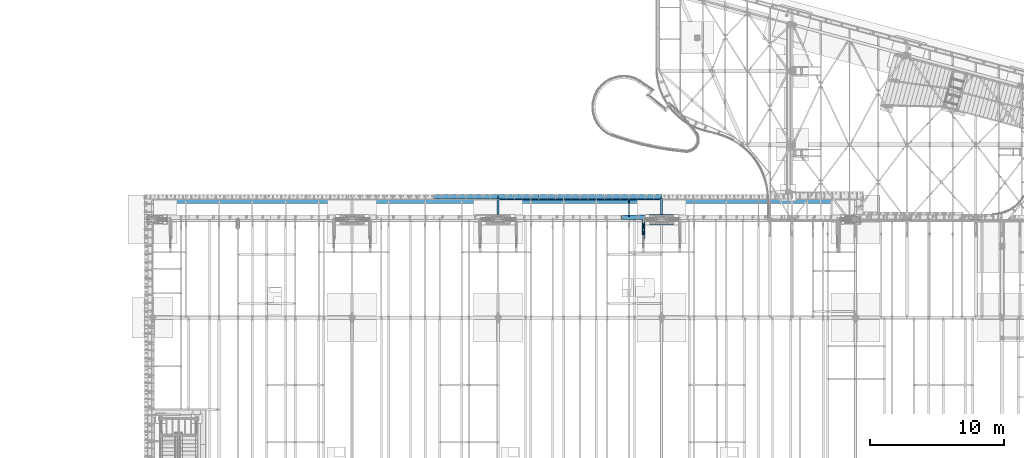
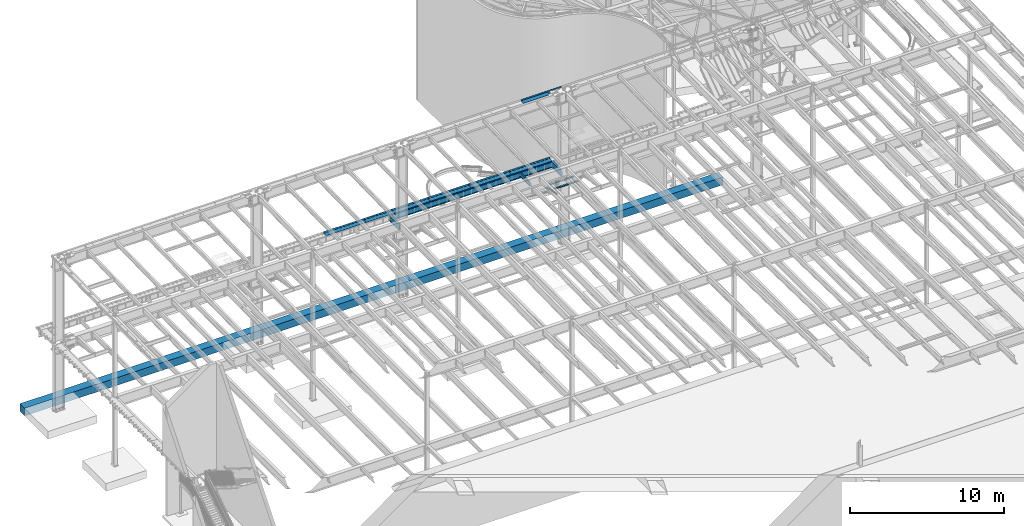
# One storey, part 1136 of 1763: 16 beams, 9 elements without a shape of their own.
"""IFC2X3 building model written with IfcOpenShell, lengths in millimetres."""

from ifc_helpers import new_model, si_unit, frame, origin_with_axes, place, context, subcontext, project, spatial, faceted_brep, material, type_object, element, aggregate, save


model = new_model("IFC2X3")

# Units and contexts
model_context = context("Model", 3, precision=1e-05, world=origin_with_axes())
body_context = subcontext(model_context, "Body", "Model", "MODEL_VIEW")
ifc_project = project(units=[si_unit("LENGTHUNIT", "METRE", prefix="MILLI"), si_unit("AREAUNIT", "SQUARE_METRE"), si_unit("VOLUMEUNIT", "CUBIC_METRE"), si_unit("MASSUNIT", "GRAM", prefix="KILO"), si_unit("TIMEUNIT", "SECOND"), si_unit("PLANEANGLEUNIT", "RADIAN"), si_unit("SOLIDANGLEUNIT", "STERADIAN"), si_unit("THERMODYNAMICTEMPERATUREUNIT", "DEGREE_CELSIUS"), si_unit("LUMINOUSINTENSITYUNIT", "LUMEN")], contexts=[model_context])

# Site, building, storey
site_placement = place(None, origin_with_axes())
site = spatial("IfcSite", under=ifc_project, at=site_placement, CompositionType="ELEMENT")
building_placement = place(site_placement, origin_with_axes())
building = spatial("IfcBuilding", under=site, at=building_placement, Name="Undefined", CompositionType="ELEMENT")
storey_placement = place(building_placement, origin_with_axes())
storey = spatial("IfcBuildingStorey", under=building, at=storey_placement, Name="Undefined", CompositionType="ELEMENT", Elevation=0.0)

# Assembly, beams
assembly_1_placement = place(storey_placement, origin_with_axes())
assembly_1 = element("IfcElementAssembly", 1, at=assembly_1_placement, inside=storey, Name="COLUMN", AssemblyPlace="NOTDEFINED", PredefinedType="RIGID_FRAME")
ifc_material_1 = material(Name="STEEL/A572-50")
beam_type_1 = type_object("IfcBeamType", PredefinedType="NOTDEFINED")
beam_1_placement = place(assembly_1_placement, frame((-48505.4997736984, 52409.725, 4433.8875), z_axis=(0.0, -1.0, 0.0), x_axis=(-1.0, 0.0, 0.0)))
beam_1 = element("IfcBeam", 2, at=beam_1_placement, type_object=beam_type_1, material=ifc_material_1, Name="PLATE", context=body_context, shape_type="Brep", body=[
    faceted_brep([(0.0, 14.2875000000004, -79.375), (0.0, 14.2875000000004, 79.375), (1793.875, 14.2875000000004, 79.375), (1793.875, 14.2875000000004, -79.375), (0.0, -14.2875000000004, 79.375), (1793.875, -14.2875000000004, 79.375), (0.0, -14.2875000000004, -79.375), (1793.875, -14.2875000000004, -79.375)], [[[0, 1, 2, 3]], [[1, 4, 5, 2]], [[4, 6, 7, 5]], [[6, 0, 3, 7]], [[5, 7, 3, 2]], [[6, 4, 1, 0]]]),
])
beam_2_placement = place(assembly_1_placement, frame((-48505.4997736984, 51831.875, 4433.8875), z_axis=(0.0, -1.0, 0.0), x_axis=(-1.0, 0.0, 0.0)))
beam_2 = element("IfcBeam", 3, at=beam_2_placement, type_object=beam_type_1, material=ifc_material_1, Name="PLATE", context=body_context, shape_type="Brep", body=[
    faceted_brep([(0.0, 14.2875000000004, -79.375), (0.0, 14.2875000000004, 79.375), (1793.875, 14.2875000000004, 79.375), (1793.875, 14.2875000000004, -79.375), (0.0, -14.2875000000004, 79.375), (1793.875, -14.2875000000004, 79.375), (0.0, -14.2875000000004, -79.375), (1793.875, -14.2875000000004, -79.375)], [[[0, 1, 2, 3]], [[1, 4, 5, 2]], [[4, 6, 7, 5]], [[6, 0, 3, 7]], [[5, 7, 3, 2]], [[6, 4, 1, 0]]]),
])
aggregate(assembly_1, [beam_1, beam_2])

assembly_2_placement = place(storey_placement, origin_with_axes())
assembly_2 = element("IfcElementAssembly", 4, at=assembly_2_placement, inside=storey, Name="ANGLE BRACE", AssemblyPlace="NOTDEFINED", PredefinedType="RIGID_FRAME")
ifc_material_2 = material(Name="STEEL/A36")
beam_type_2 = type_object("IfcBeamType", Name="L4X3X5/16", PredefinedType="NOTDEFINED")
beam_3_placement = place(assembly_2_placement, frame((-50799.4372736984, 50680.4564530846, 4820.75267554856), z_axis=(0.0, -0.2072236520035, -0.978293595016513), x_axis=(0.0, 0.978293600950479, -0.20722362398951)))
beam_3 = element("IfcBeam", 5, at=beam_3_placement, type_object=beam_type_2, material=ifc_material_2, Name="ANGLE BRACE", ObjectType="L4X3X5/16", context=body_context, shape_type="Brep", body=[
    faceted_brep([(1.45519152283669e-10, 38.0999999999985, -50.7999999999993), (1.45519152283669e-10, 38.0999999999985, 50.7999999999993), (1427.42255777739, 38.0999999999985, 50.7999999995518), (1427.42255777754, 38.0999999999985, -50.8000000004868), (-7.27595761418343e-11, 30.1624999999985, 50.8000000000211), (1427.42255777739, 30.1624999999985, 50.7999999995518), (7.27595761418343e-11, 30.1624999999985, -42.8625000000175), (1427.42255777754, 30.1624999999985, -42.8625000004868), (7.27595761418343e-11, -38.0999999999985, -42.8625000000175), (1427.42255777754, -38.0999999999985, -42.8625000004868), (-1.23691279441118e-10, -38.1000000000022, -50.7999999999993), (1427.42255777754, -38.0999999999985, -50.8000000004868)], [[[0, 1, 2, 3]], [[1, 4, 5, 2]], [[4, 6, 7, 5]], [[6, 8, 9, 7]], [[8, 10, 11, 9]], [[10, 0, 3, 11]], [[5, 7, 9, 11, 3, 2]], [[10, 8, 6, 4, 1, 0]]]),
])
beam_4_placement = place(assembly_2_placement, frame((-50713.7122736983, 52076.9355387112, 4524.94833056974), z_axis=(0.0, -0.2072236520035, -0.978293595016513), x_axis=(0.0, -0.978293595016513, 0.207223652003498)))
beam_4 = element("IfcBeam", 6, at=beam_4_placement, type_object=beam_type_2, material=ifc_material_2, Name="ANGLE BRACE", ObjectType="L4X3X5/16", context=body_context, shape_type="Brep", body=[
    faceted_brep([(1.45519152283669e-10, 38.0999999999985, -50.7999999999993), (1.45519152283669e-10, 38.0999999999985, 50.7999999999993), (1427.46422513096, 38.0999999999985, 50.7999999991189), (1427.46422513096, 38.0999999999985, -50.8000000008396), (-7.27595761418343e-11, 30.1624999999985, 50.8000000000211), (1427.46422513096, 30.1624999999985, 50.7999999991189), (7.27595761418343e-11, 30.1624999999985, -42.8625000000175), (1427.46422513096, 30.1624999999985, -42.8625000008433), (7.27595761418343e-11, -38.0999999999985, -42.8625000000175), (1427.46422513096, -38.0999999999985, -42.8625000008433), (-1.23691279441118e-10, -38.1000000000022, -50.7999999999993), (1427.46422513096, -38.0999999999985, -50.8000000008396)], [[[0, 1, 2, 3]], [[1, 4, 5, 2]], [[4, 6, 7, 5]], [[6, 8, 9, 7]], [[8, 10, 11, 9]], [[10, 0, 3, 11]], [[5, 7, 9, 11, 3, 2]], [[10, 8, 6, 4, 1, 0]]]),
])
aggregate(assembly_2, [beam_3, beam_4])

# Assembly, beam
assembly_3_placement = place(storey_placement, origin_with_axes())
assembly_3 = element("IfcElementAssembly", 7, at=assembly_3_placement, inside=storey, Name="BEAM", AssemblyPlace="NOTDEFINED", PredefinedType="RIGID_FRAME")
beam_type_3 = type_object("IfcBeamType", PredefinedType="NOTDEFINED")
beam_5_placement = place(assembly_3_placement, frame((-50926.4372736983, 52133.5000002128, 11752.2624917654), z_axis=(-1.0, 0.0, 0.0), x_axis=(0.0, 1.0, 0.0)))
beam_5 = element("IfcBeam", 8, at=beam_5_placement, type_object=beam_type_3, material=ifc_material_2, Name="BENT_PLATE", context=body_context, shape_type="Brep", body=[
    faceted_brep([(0.0, -4.76250000000073, -392.112609374992), (0.0, 4.76250000000073, -392.112609374992), (133.350000000006, 4.76250000000073, -392.112609374992), (133.350000000006, -4.76250000000073, -392.112609374992), (133.350000000006, 4.76250000000073, -595.31249951171), (133.350000000006, -4.76250000000073, -595.31249951171), (327.024987792967, -4.76250000000073, -595.31347607421), (327.024987792967, 4.76250000000073, -595.31347607421), (327.024987792975, 4.76250000000073, -1520.8245), (327.024987792975, -4.76250000000073, -1520.8245), (336.549987792969, 4.76250000000073, 1520.8245), (0.0, 4.76250000000073, 1520.8245), (0.0, -4.76250000000073, 1520.8245), (327.024987792975, -4.76250000000073, 1520.8245), (327.024987792975, -122.237499999999, 1520.8245), (336.549987792969, -122.237499999999, 1520.8245), (336.549987792969, 4.76250000000073, -1520.8245), (336.549987792969, -122.237499999999, -1520.8245), (327.024987792975, -122.237499999999, -1520.8245), (327.024987792975, -99.5375007629336, -1520.8245)], [[[0, 1, 2, 3]], [[3, 2, 4, 5]], [[6, 7, 8, 9]], [[5, 4, 7, 6]], [[10, 11, 12, 13, 14, 15]], [[16, 10, 15, 17]], [[14, 18, 17, 15]], [[13, 6, 9, 19, 18, 14]], [[16, 17, 18, 19, 9, 8]], [[2, 1, 11, 10, 16, 8, 7, 4]], [[12, 11, 1, 0]], [[13, 12, 0, 3, 5, 6]]]),
])
aggregate(assembly_3, [beam_5])

assembly_4_placement = place(storey_placement, origin_with_axes())
assembly_4 = element("IfcElementAssembly", 9, at=assembly_4_placement, inside=storey, Name="BEAM", AssemblyPlace="NOTDEFINED", PredefinedType="RIGID_FRAME")
beam_type_4 = type_object("IfcBeamType", PredefinedType="NOTDEFINED")
beam_6_placement = place(assembly_4_placement, frame((-62470.7372736984, 53657.5, 5199.0625), z_axis=(1.0, 0.0, 0.0), x_axis=(0.0, 1.0, 0.0)))
beam_6 = element("IfcBeam", 10, at=beam_6_placement, type_object=beam_type_4, material=ifc_material_2, Name="BENT PLATE", context=body_context, shape_type="Brep", body=[
    faceted_brep([(0.0, -4.76249999999982, -876.300000000003), (0.0, -4.76249999999982, 876.300000000003), (0.0, 4.76249999999982, 876.300000000003), (0.0, 4.76249999999982, -876.300000000003), (327.025018310553, 4.76249999999982, 876.300000000003), (327.025018310553, 4.76249999999982, -876.300000000003), (336.550018310547, -4.76249999999982, -876.300000000003), (336.550018310547, -4.76249999999982, 876.300000000003), (327.025018310553, 134.937496948242, 876.300000000003), (327.025018310553, 134.937496948242, -876.300000000003), (336.550018310547, 134.937496948242, 876.300000000003), (336.550018310547, 134.937496948242, -876.300000000003)], [[[0, 1, 2, 3]], [[3, 2, 4, 5]], [[1, 0, 6, 7]], [[5, 4, 8, 9]], [[4, 2, 1, 7, 10, 8]], [[7, 6, 11, 10]], [[6, 0, 3, 5, 9, 11]], [[10, 11, 9, 8]]]),
])

# Assembly, beams
assembly_5_placement = place(storey_placement, origin_with_axes())
assembly_5 = element("IfcElementAssembly", 11, at=assembly_5_placement, inside=storey, Name="BEAM", AssemblyPlace="NOTDEFINED", PredefinedType="RIGID_FRAME")
beam_7_placement = place(assembly_5_placement, frame((-50926.4372736983, 53657.5, 5199.0625), z_axis=(1.0, 0.0, 0.0), x_axis=(0.0, 1.0, 0.0)))
beam_7 = element("IfcBeam", 12, at=beam_7_placement, type_object=beam_type_4, material=ifc_material_2, Name="BENT PLATE", context=body_context, shape_type="Brep", body=[
    faceted_brep([(0.0, -4.76249999999982, -1524.0), (0.0, -4.76249999999982, 1524.0), (0.0, 4.76249999999982, 1524.0), (0.0, 4.76249999999982, -1524.0), (327.024987792967, 4.76250000000073, 1524.0), (327.025018310553, 4.76249999999982, -1524.0), (336.550018310547, -4.76249999999982, -1524.0), (336.550018310547, -4.76249999999982, 1524.0), (327.025018310553, 134.937496948242, 1524.0), (327.025018310553, 134.937496948242, -1524.0), (336.550018310547, 134.937496948242, 1524.0), (336.550018310547, 134.937496948242, -1524.0)], [[[0, 1, 2, 3]], [[3, 2, 4, 5]], [[1, 0, 6, 7]], [[5, 4, 8, 9]], [[4, 2, 1, 7, 10, 8]], [[7, 6, 11, 10]], [[6, 0, 3, 5, 9, 11]], [[10, 11, 9, 8]]]),
])
beam_8_placement = place(assembly_5_placement, frame((-53974.4372736983, 53657.5, 5199.0625), z_axis=(1.0, 0.0, 0.0), x_axis=(0.0, 1.0, 0.0)))
beam_8 = element("IfcBeam", 13, at=beam_8_placement, type_object=beam_type_4, material=ifc_material_2, Name="BENT PLATE", context=body_context, shape_type="Brep", body=[
    faceted_brep([(0.0, -4.76249999999982, -1524.0), (0.0, -4.76249999999982, 1524.0), (0.0, 4.76249999999982, 1524.0), (0.0, 4.76249999999982, -1524.0), (327.024987792967, 4.76250000000073, 1524.0), (327.025018310553, 4.76249999999982, -1524.0), (336.550018310547, -4.76249999999982, -1524.0), (336.550018310547, -4.76249999999982, 1524.0), (327.025018310553, 134.937496948242, 1524.0), (327.025018310553, 134.937496948242, -1524.0), (336.550018310547, 134.937496948242, 1524.0), (336.550018310547, 134.937496948242, -1524.0)], [[[0, 1, 2, 3]], [[3, 2, 4, 5]], [[1, 0, 6, 7]], [[5, 4, 8, 9]], [[4, 2, 1, 7, 10, 8]], [[7, 6, 11, 10]], [[6, 0, 3, 5, 9, 11]], [[10, 11, 9, 8]]]),
])
beam_9_placement = place(assembly_5_placement, frame((-57022.4372736983, 53657.5, 5199.0625), z_axis=(1.0, 0.0, 0.0), x_axis=(0.0, 1.0, 0.0)))
beam_9 = element("IfcBeam", 14, at=beam_9_placement, type_object=beam_type_4, material=ifc_material_2, Name="BENT PLATE", context=body_context, shape_type="Brep", body=[
    faceted_brep([(0.0, -4.76249999999982, -1524.0), (0.0, -4.76249999999982, 1524.0), (0.0, 4.76249999999982, 1524.0), (0.0, 4.76249999999982, -1524.0), (327.024987792967, 4.76250000000073, 1524.0), (327.025018310553, 4.76249999999982, -1524.0), (336.550018310547, -4.76249999999982, -1524.0), (336.550018310547, -4.76249999999982, 1524.0), (327.025018310553, 134.937496948242, 1524.0), (327.025018310553, 134.937496948242, -1524.0), (336.550018310547, 134.937496948242, 1524.0), (336.550018310547, 134.937496948242, -1524.0)], [[[0, 1, 2, 3]], [[3, 2, 4, 5]], [[1, 0, 6, 7]], [[5, 4, 8, 9]], [[4, 2, 1, 7, 10, 8]], [[7, 6, 11, 10]], [[6, 0, 3, 5, 9, 11]], [[10, 11, 9, 8]]]),
])
beam_10_placement = place(assembly_5_placement, frame((-60070.4372736983, 53657.5, 5199.0625), z_axis=(1.0, 0.0, 0.0), x_axis=(0.0, 1.0, 0.0)))
beam_10 = element("IfcBeam", 15, at=beam_10_placement, type_object=beam_type_4, material=ifc_material_2, Name="BENT PLATE", context=body_context, shape_type="Brep", body=[
    faceted_brep([(0.0, -4.76249999999982, -1524.0), (0.0, -4.76249999999982, 1524.0), (0.0, 4.76249999999982, 1524.0), (0.0, 4.76249999999982, -1524.0), (327.024987792967, 4.76250000000073, 1524.0), (327.025018310553, 4.76249999999982, -1524.0), (336.550018310547, -4.76249999999982, -1524.0), (336.550018310547, -4.76249999999982, 1524.0), (327.025018310553, 134.937496948242, 1524.0), (327.025018310553, 134.937496948242, -1524.0), (336.550018310547, 134.937496948242, 1524.0), (336.550018310547, 134.937496948242, -1524.0)], [[[0, 1, 2, 3]], [[3, 2, 4, 5]], [[1, 0, 6, 7]], [[5, 4, 8, 9]], [[4, 2, 1, 7, 10, 8]], [[7, 6, 11, 10]], [[6, 0, 3, 5, 9, 11]], [[10, 11, 9, 8]]]),
])

# Beam
beam_11_placement = place(assembly_4_placement, frame((-64871.0372736984, 53657.5, 5199.0625), z_axis=(1.0, 0.0, 0.0), x_axis=(0.0, 1.0, 0.0)))
beam_11 = element("IfcBeam", 16, at=beam_11_placement, type_object=beam_type_4, material=ifc_material_2, Name="BENT PLATE", context=body_context, shape_type="Brep", body=[
    faceted_brep([(0.0, -4.76249999999982, -1524.0), (0.0, -4.76249999999982, 1524.0), (0.0, 4.76249999999982, 1524.0), (0.0, 4.76249999999982, -1524.0), (327.024987792967, 4.76250000000073, 1524.0), (327.025018310553, 4.76249999999982, -1524.0), (336.550018310547, -4.76249999999982, -1524.0), (336.550018310547, -4.76249999999982, 1524.0), (327.025018310553, 134.937496948242, 1524.0), (327.025018310553, 134.937496948242, -1524.0), (336.550018310547, 134.937496948242, 1524.0), (336.550018310547, 134.937496948242, -1524.0)], [[[0, 1, 2, 3]], [[3, 2, 4, 5]], [[1, 0, 6, 7]], [[5, 4, 8, 9]], [[4, 2, 1, 7, 10, 8]], [[7, 6, 11, 10]], [[6, 0, 3, 5, 9, 11]], [[10, 11, 9, 8]]]),
])

aggregate(assembly_4, [beam_6, beam_11])

# Assembly, beam
assembly_6_placement = place(storey_placement, origin_with_axes())
assembly_6 = element("IfcElementAssembly", 17, at=assembly_6_placement, inside=storey, Name="BEAM", AssemblyPlace="NOTDEFINED", PredefinedType="RIGID_FRAME")
ifc_material_3 = material(Name="STEEL/A992")
beam_type_5 = type_object("IfcBeamType", Name="W12X16", PredefinedType="NOTDEFINED")
beam_12_placement = place(assembly_6_placement, frame((-51840.8372736984, 52120.8, 5041.9), z_axis=(0.0, 0.0, 1.0), x_axis=(0.0, 1.0, 0.0)))
beam_12 = element("IfcBeam", 18, at=beam_12_placement, type_object=beam_type_5, material=ifc_material_3, Name="BEAM", ObjectType="W12X16", context=body_context, shape_type="Brep", body=[
    faceted_brep([(20.6374999999971, -3.17500000000291, -114.3), (20.6374999999971, 3.17500000000291, -114.3), (192.087500190733, 3.17500000000291, -114.3), (192.087500190733, -3.17500000000291, -114.3), (196.94757970878, 3.17500000000291, -115.266729922588), (196.94757970878, -3.17500000000291, -115.266729922588), (201.067756176933, 3.17500000000291, -118.019743823066), (201.067756176933, -3.17500000000291, -118.019743823066), (203.820770077407, 3.17500000000291, -122.13992029122), (203.820770077407, -3.17500000000291, -122.13992029122), (204.787499999999, -3.17500000000291, -126.999999809265), (204.787499999999, 3.17500000000291, -126.999999809265), (204.787499999999, 3.17500000000291, -146.05), (204.787499999999, 50.8000000000029, -146.05), (204.787499999999, 50.8000000000029, -152.4), (204.787499999999, -50.8000000000029, -152.4), (204.787499999999, -50.8000000000029, -146.05), (204.787499999999, -3.17500000000291, -146.05), (1431.13125000001, 50.8000000000029, 146.05), (1431.13125000001, 3.17500000000291, 146.05), (204.787499999999, 3.17500000000291, 146.05), (204.787499999999, 50.8000000000029, 146.05), (192.087500190733, -3.17500000000291, 114.3), (192.087500190733, 3.17500000000291, 114.3), (20.6374999999971, 3.17500000000291, 114.3), (20.6374999999971, -3.17500000000291, 114.3), (196.94757970878, -3.17500000000291, 115.266729922588), (196.94757970878, 3.17500000000291, 115.266729922588), (201.067756176933, -3.17500000000291, 118.019743823066), (201.067756176933, 3.17500000000291, 118.019743823066), (203.820770077407, -3.17500000000291, 122.13992029122), (203.820770077407, 3.17500000000291, 122.13992029122), (204.787499999999, -3.17500000000291, 126.999999809265), (204.787499999999, 3.17500000000291, 126.999999809265), (1431.13125000001, -50.8000000000029, 152.4), (1431.13125000001, 50.8000000000029, 152.4), (204.787499999999, 50.8000000000029, 152.4), (204.787499999999, -50.8000000000029, 152.4), (1431.13125000001, -50.8000000000029, 146.05), (204.787499999999, -50.8000000000029, 146.05), (1431.13125000001, -3.17500000000291, 146.05), (204.787499999999, -3.17500000000291, 146.05), (1431.13125000001, -3.17500000000291, 139.440001487732), (1431.13125000001, 3.17500000000291, 139.440001487732), (1432.0979799226, -3.17500000000291, 134.579921969686), (1432.0979799226, 3.17500000000291, 134.579921969686), (1434.85099382307, -3.17500000000291, 130.459745501533), (1434.85099382307, 3.17500000000291, 130.459745501533), (1438.97117029122, -3.17500000000291, 127.706731601054), (1438.97117029122, 3.17500000000291, 127.706731601054), (1443.83124980927, -3.17500000000291, 126.740001678467), (1443.83124980927, 3.17500000000291, 126.740001678467), (1507.33125, -3.17500000000291, 126.740001678467), (1507.33125, 3.17500000000291, 126.740001678467), (1507.33125, -3.17500000000291, -146.05), (1507.33125, -50.8000000000029, -146.05), (1507.33125, -50.8000000000029, -152.4), (1507.33125, 50.8000000000029, -152.4), (1507.33125, 50.8000000000029, -146.05), (1507.33125, 3.17500000000291, -146.05)], [[[0, 1, 2, 3]], [[3, 2, 4, 5]], [[5, 4, 6, 7]], [[7, 6, 8, 9]], [[10, 11, 12, 13, 14, 15, 16, 17]], [[9, 8, 11, 10]], [[18, 19, 20, 21]], [[22, 23, 24, 25]], [[26, 27, 23, 22]], [[28, 29, 27, 26]], [[30, 31, 29, 28]], [[32, 33, 31, 30]], [[34, 35, 36, 37]], [[38, 34, 37, 39]], [[40, 38, 39, 41]], [[37, 36, 21, 20, 33, 32, 41, 39]], [[35, 18, 21, 36]], [[34, 38, 40, 42, 43, 19, 18, 35]], [[44, 45, 43, 42]], [[46, 47, 45, 44]], [[48, 49, 47, 46]], [[50, 51, 49, 48]], [[52, 53, 51, 50]], [[54, 55, 56, 57, 58, 59, 53, 52]], [[55, 54, 17, 16]], [[56, 55, 16, 15]], [[57, 56, 15, 14]], [[58, 57, 14, 13]], [[59, 58, 13, 12]], [[6, 4, 2, 1, 24, 23, 27, 29, 31, 33, 20, 19, 43, 45, 47, 49, 51, 53, 59, 12, 11, 8]], [[25, 24, 1, 0]], [[54, 52, 50, 48, 46, 44, 42, 40, 41, 32, 30, 28, 26, 22, 25, 0, 3, 5, 7, 9, 10, 17]]]),
])
aggregate(assembly_6, [beam_12])

assembly_7_placement = place(storey_placement, origin_with_axes())
assembly_7 = element("IfcElementAssembly", 19, at=assembly_7_placement, inside=storey, Name="BEAM", AssemblyPlace="NOTDEFINED", PredefinedType="RIGID_FRAME")
beam_type_6 = type_object("IfcBeamType", Name="W18X40", PredefinedType="NOTDEFINED")
beam_13_placement = place(assembly_7_placement, frame((-49402.4372736983, 52120.8, 4967.2875), z_axis=(0.0, 0.0, 1.0), x_axis=(0.0, 1.0, 0.0)))
beam_13 = element("IfcBeam", 20, at=beam_13_placement, type_object=beam_type_6, material=ifc_material_3, Name="BEAM", ObjectType="W18X40", context=body_context, shape_type="Brep", body=[
    faceted_brep([(385.15757393559, -76.1999999999971, 227.0125), (385.15757393559, 76.1999999999971, 227.0125), (377.825012672634, 76.1999999999971, 214.3125), (377.825012672634, 3.96875, 214.3125), (377.595797451308, 3.96875, 213.91549911499), (377.595797451308, -3.96875, 213.91549911499), (377.825012672634, -3.96875, 214.3125), (377.825012672634, -76.1999999999971, 214.3125), (403.224996948229, -3.96875, 213.91549911499), (403.224996948229, 3.96875, 213.91549911499), (424.434101018858, 3.96875, 204.211830867132), (424.434101018858, -3.96875, 204.211830867132), (427.472016714142, 3.96875, 201.276913128712), (427.472016714142, -3.96875, 201.276913128712), (427.996621366721, 3.96875, 197.085557278698), (427.996621366721, -3.96875, 197.085557278698), (425.775777831688, 3.96875, 193.492434974088), (425.775777831688, -3.96875, 193.492434974088), (421.792207621249, 3.96875, 192.0875), (421.792207621249, -3.96875, 192.0875), (225.424999999988, 3.96875, 192.0875), (225.424999999988, -3.96875, 192.0875), (225.424999999988, 3.96875, -192.0875), (225.424999999988, -3.96875, -192.0875), (334.333211039215, 3.96875, -192.0875), (334.333211039215, -3.96875, -192.0875), (338.316781249654, 3.96875, -193.492434974089), (338.316781249654, -3.96875, -193.492434974089), (340.537624784687, 3.96875, -197.085557278698), (340.537624784687, -3.96875, -197.085557278698), (340.013020132108, 3.96875, -201.276913128712), (340.013020132108, -3.96875, -201.276913128712), (336.975104436824, 3.96875, -204.211830867132), (336.975104436824, -3.96875, -204.211830867132), (315.766000366195, 3.96875, -213.91549911499), (315.766000366195, -3.96875, -213.91549911499), (1600.2, 3.96875, -214.3125), (1600.2, 76.1999999999971, -214.3125), (315.307591212309, 76.1999999999971, -214.3125), (315.307591212309, 3.96875, -214.3125), (1600.2, 76.1999999999971, -227.0125), (1600.2, -76.1999999999971, -227.0125), (307.975402928918, -76.1999999999971, -227.0125), (307.975402928918, 76.1999999999971, -227.0125), (1600.2, -76.1999999999971, -214.3125), (315.307591212309, -76.1999999999971, -214.3125), (1600.2, -3.96875, -214.3125), (315.307591212309, -3.96875, -214.3125), (1600.2, 3.96875, 214.3125), (1600.2, 76.1999999999971, 214.3125), (1600.2, 76.1999999999971, 227.0125), (1600.2, -76.1999999999971, 227.0125), (1600.2, -76.1999999999971, 214.3125), (1600.2, -3.96875, 214.3125)], [[[0, 1, 2, 3, 4, 5, 6, 7]], [[8, 9, 10, 11]], [[11, 10, 12, 13]], [[13, 12, 14, 15]], [[15, 14, 16, 17]], [[17, 16, 18, 19]], [[19, 18, 20, 21]], [[21, 20, 22, 23]], [[24, 25, 23, 22]], [[25, 24, 26, 27]], [[27, 26, 28, 29]], [[29, 28, 30, 31]], [[31, 30, 32, 33]], [[33, 32, 34, 35]], [[36, 37, 38, 39]], [[40, 41, 42, 43]], [[41, 44, 45, 42]], [[44, 46, 47, 45]], [[35, 34, 39, 38, 43, 42, 45, 47]], [[37, 40, 43, 38]], [[36, 48, 49, 50, 51, 52, 53, 46, 44, 41, 40, 37]], [[52, 51, 0, 7]], [[53, 52, 7, 6]], [[8, 11, 13, 15, 17, 19, 21, 23, 25, 27, 29, 31, 33, 35, 47, 46, 53, 6, 5]], [[9, 8, 5, 4]], [[48, 36, 39, 34, 32, 30, 28, 26, 24, 22, 20, 18, 16, 14, 12, 10, 9, 4, 3]], [[49, 48, 3, 2]], [[50, 49, 2, 1]], [[51, 50, 1, 0]]]),
])
aggregate(assembly_7, [beam_13])

assembly_8_placement = place(storey_placement, origin_with_axes())
assembly_8 = element("IfcElementAssembly", 21, at=assembly_8_placement, inside=storey, Name="BEAM", AssemblyPlace="NOTDEFINED", PredefinedType="RIGID_FRAME")
beam_14_placement = place(assembly_8_placement, frame((-61594.4372736983, 52120.8, 4967.2875), z_axis=(0.0, 0.0, 1.0), x_axis=(0.0, 1.0, 0.0)))
beam_14 = element("IfcBeam", 22, at=beam_14_placement, type_object=beam_type_6, material=ifc_material_3, Name="BEAM", ObjectType="W18X40", context=body_context, shape_type="Brep", body=[
    faceted_brep([(385.15757393559, -76.1999999999971, 227.0125), (385.15757393559, 76.1999999999971, 227.0125), (377.825012672634, 76.1999999999971, 214.3125), (377.825012672634, 3.96875, 214.3125), (377.595797451308, 3.96875, 213.91549911499), (377.595797451308, -3.96875, 213.91549911499), (377.825012672634, -3.96875, 214.3125), (377.825012672634, -76.1999999999971, 214.3125), (403.224996948229, -3.96875, 213.91549911499), (403.224996948229, 3.96875, 213.91549911499), (424.434101018858, 3.96875, 204.211830867132), (424.434101018858, -3.96875, 204.211830867132), (427.472016714142, 3.96875, 201.276913128712), (427.472016714142, -3.96875, 201.276913128712), (427.996621366721, 3.96875, 197.085557278698), (427.996621366721, -3.96875, 197.085557278698), (425.775777831688, 3.96875, 193.492434974088), (425.775777831688, -3.96875, 193.492434974088), (421.792207621249, 3.96875, 192.0875), (421.792207621249, -3.96875, 192.0875), (225.424999999988, 3.96875, 192.0875), (225.424999999988, -3.96875, 192.0875), (225.424999999988, 3.96875, -192.0875), (225.424999999988, -3.96875, -192.0875), (334.333211039215, 3.96875, -192.0875), (334.333211039215, -3.96875, -192.0875), (338.316781249654, 3.96875, -193.492434974089), (338.316781249654, -3.96875, -193.492434974089), (340.537624784687, 3.96875, -197.085557278698), (340.537624784687, -3.96875, -197.085557278698), (340.013020132108, 3.96875, -201.276913128712), (340.013020132108, -3.96875, -201.276913128712), (336.975104436824, 3.96875, -204.211830867132), (336.975104436824, -3.96875, -204.211830867132), (315.766000366195, 3.96875, -213.91549911499), (315.766000366195, -3.96875, -213.91549911499), (1600.2, 3.96875, -214.3125), (1600.2, 76.1999999999971, -214.3125), (315.307591212309, 76.1999999999971, -214.3125), (315.307591212309, 3.96875, -214.3125), (1600.2, 76.1999999999971, -227.0125), (1600.2, -76.1999999999971, -227.0125), (307.975402928918, -76.1999999999971, -227.0125), (307.975402928918, 76.1999999999971, -227.0125), (1600.2, -76.1999999999971, -214.3125), (315.307591212309, -76.1999999999971, -214.3125), (1600.2, -3.96875, -214.3125), (315.307591212309, -3.96875, -214.3125), (1600.2, 3.96875, 214.3125), (1600.2, 76.1999999999971, 214.3125), (1600.2, 76.1999999999971, 227.0125), (1600.2, -76.1999999999971, 227.0125), (1600.2, -76.1999999999971, 214.3125), (1600.2, -3.96875, 214.3125)], [[[0, 1, 2, 3, 4, 5, 6, 7]], [[8, 9, 10, 11]], [[11, 10, 12, 13]], [[13, 12, 14, 15]], [[15, 14, 16, 17]], [[17, 16, 18, 19]], [[19, 18, 20, 21]], [[21, 20, 22, 23]], [[24, 25, 23, 22]], [[25, 24, 26, 27]], [[27, 26, 28, 29]], [[29, 28, 30, 31]], [[31, 30, 32, 33]], [[33, 32, 34, 35]], [[36, 37, 38, 39]], [[40, 41, 42, 43]], [[41, 44, 45, 42]], [[44, 46, 47, 45]], [[35, 34, 39, 38, 43, 42, 45, 47]], [[37, 40, 43, 38]], [[36, 48, 49, 50, 51, 52, 53, 46, 44, 41, 40, 37]], [[52, 51, 0, 7]], [[53, 52, 7, 6]], [[8, 11, 13, 15, 17, 19, 21, 23, 25, 27, 29, 31, 33, 35, 47, 46, 53, 6, 5]], [[9, 8, 5, 4]], [[48, 36, 39, 34, 32, 30, 28, 26, 24, 22, 20, 18, 16, 14, 12, 10, 9, 4, 3]], [[49, 48, 3, 2]], [[50, 49, 2, 1]], [[51, 50, 1, 0]]]),
])
aggregate(assembly_8, [beam_14])

# Beam
beam_15_placement = place(assembly_5_placement, frame((-61594.4372736983, 53644.8, 4967.2875), z_axis=(0.0, 0.0, 1.0), x_axis=(1.0, 0.0, 0.0)))
beam_15 = element("IfcBeam", 23, at=beam_15_placement, type_object=beam_type_6, material=ifc_material_3, Name="BEAM", ObjectType="W18X40", context=body_context, shape_type="Brep", body=[
    faceted_brep([(12102.30625, -3.96875, -214.3125), (12102.30625, -76.1999999999971, -214.3125), (12102.30625, -76.1999999999971, -227.0125), (12102.30625, 76.1999999999971, -227.0125), (12102.30625, 76.1999999999971, -214.3125), (12102.30625, 3.96875, -214.3125), (12102.30625, 3.96875, -208.222499809265), (12102.30625, -3.96875, -208.222499809265), (12103.2729799226, 3.96875, -203.36242029122), (12103.2729799226, -3.96875, -203.36242029122), (12106.0259938231, 3.96875, -199.242243823066), (12106.0259938231, -3.96875, -199.242243823066), (12110.1461702912, 3.96875, -196.489229922588), (12110.1461702912, -3.96875, -196.489229922588), (12115.0062498093, 3.96875, -195.5225), (12115.0062498093, -3.96875, -195.5225), (12175.33125, -3.96875, -195.5225), (12175.33125, 3.96875, -195.5225), (89.6937500000058, 3.96875, 214.3125), (89.6937500000058, 76.1999999999971, 214.3125), (12102.30625, 76.1999999999971, 214.3125), (12102.30625, 3.96875, 214.3125), (89.6937500000058, -3.96875, -208.222499809265), (89.6937500000058, 3.96875, -208.222499809265), (89.6937500000058, 3.96875, -214.3125), (89.6937500000058, 76.1999999999971, -214.3125), (89.6937500000058, 76.1999999999971, -227.0125), (89.6937500000058, -76.1999999999971, -227.0125), (89.6937500000058, -76.1999999999971, -214.3125), (89.6937500000058, -3.96875, -214.3125), (88.7270200774146, -3.96875, -203.36242029122), (88.7270200774146, 3.96875, -203.36242029122), (85.9740061769407, -3.96875, -199.242243823066), (85.9740061769407, 3.96875, -199.242243823066), (81.8538297087871, -3.96875, -196.489229922588), (81.8538297087871, 3.96875, -196.489229922588), (76.9937501907407, -3.96875, -195.5225), (76.9937501907407, 3.96875, -195.5225), (16.6687499999971, -3.96875, -195.5225), (16.6687499999971, 3.96875, -195.5225), (16.6687499999971, -3.96875, 195.002501678467), (16.6687499999971, 3.96875, 195.002501678467), (76.9937501907407, -3.96875, 195.002501678467), (76.9937501907407, 3.96875, 195.002501678467), (81.8538297087871, -3.96875, 195.969231601054), (81.8538297087871, 3.96875, 195.969231601054), (85.9740061769407, -3.96875, 198.722245501533), (85.9740061769407, 3.96875, 198.722245501533), (88.7270200774146, -3.96875, 202.842421969686), (88.7270200774146, 3.96875, 202.842421969686), (89.6937500000058, -3.96875, 207.702501487732), (89.6937500000058, 3.96875, 207.702501487732), (89.6937500000058, -76.1999999999971, 227.0125), (89.6937500000058, 76.1999999999971, 227.0125), (89.6937500000058, -3.96875, 214.3125), (89.6937500000058, -76.1999999999971, 214.3125), (12102.30625, -3.96875, 214.3125), (12102.30625, -76.1999999999971, 214.3125), (12102.30625, -76.1999999999971, 227.0125), (12102.30625, 76.1999999999971, 227.0125), (12102.30625, -3.96875, 207.702501487732), (12102.30625, 3.96875, 207.702501487732), (12103.2729799226, -3.96875, 202.842421969686), (12103.2729799226, 3.96875, 202.842421969686), (12106.0259938231, -3.96875, 198.722245501533), (12106.0259938231, 3.96875, 198.722245501533), (12110.1461702912, -3.96875, 195.969231601054), (12110.1461702912, 3.96875, 195.969231601054), (12115.0062498093, -3.96875, 195.002501678467), (12115.0062498093, 3.96875, 195.002501678467), (12175.33125, -3.96875, 195.002501678467), (12175.33125, 3.96875, 195.002501678467)], [[[0, 1, 2, 3, 4, 5, 6, 7]], [[7, 6, 8, 9]], [[9, 8, 10, 11]], [[11, 10, 12, 13]], [[13, 12, 14, 15]], [[16, 15, 14, 17]], [[18, 19, 20, 21]], [[22, 23, 24, 25, 26, 27, 28, 29]], [[30, 31, 23, 22]], [[32, 33, 31, 30]], [[34, 35, 33, 32]], [[36, 37, 35, 34]], [[38, 39, 37, 36]], [[40, 41, 39, 38]], [[42, 43, 41, 40]], [[44, 45, 43, 42]], [[46, 47, 45, 44]], [[48, 49, 47, 46]], [[50, 51, 49, 48]], [[52, 53, 19, 18, 51, 50, 54, 55]], [[55, 54, 56, 57]], [[52, 55, 57, 58]], [[53, 52, 58, 59]], [[19, 53, 59, 20]], [[58, 57, 56, 60, 61, 21, 20, 59]], [[62, 63, 61, 60]], [[64, 65, 63, 62]], [[66, 67, 65, 64]], [[68, 69, 67, 66]], [[70, 71, 69, 68]], [[71, 70, 16, 17]], [[12, 10, 8, 6, 5, 24, 23, 31, 33, 35, 37, 39, 41, 43, 45, 47, 49, 51, 18, 21, 61, 63, 65, 67, 69, 71, 17, 14]], [[25, 24, 5, 4]], [[26, 25, 4, 3]], [[27, 26, 3, 2]], [[28, 27, 2, 1]], [[29, 28, 1, 0]], [[70, 68, 66, 64, 62, 60, 56, 54, 50, 48, 46, 44, 42, 40, 38, 36, 34, 32, 30, 22, 29, 0, 7, 9, 11, 13, 15, 16]]]),
])

aggregate(assembly_5, [beam_7, beam_8, beam_9, beam_10, beam_15])

# Assembly, beam
assembly_9_placement = place(storey_placement, origin_with_axes())
assembly_9 = element("IfcElementAssembly", 24, at=assembly_9_placement, inside=storey, Name="BEAM", AssemblyPlace="NOTDEFINED", PredefinedType="REINFORCEMENT_UNIT")
ifc_material_4 = material(Name="CONCRETE/5000")
beam_type_7 = type_object("IfcBeamType", PredefinedType="NOTDEFINED")
beam_16_placement = place(assembly_9_placement, frame((-89204.2372736984, 53644.8, -609.6), z_axis=(0.0, 0.0, 1.0), x_axis=(1.0, 0.0, 0.0)))
beam_16 = element("IfcBeam", 25, at=beam_16_placement, type_object=beam_type_7, material=ifc_material_4, Name="BEAM", context=body_context, shape_type="Brep", body=[
    faceted_brep([(0.0, 304.799999999999, -304.8), (0.0, 304.799999999999, 304.8), (52425.6, 304.800000000003, 304.8), (52425.6, 304.800000000003, -304.8), (0.0, -304.799999999999, 304.8), (52425.6, -304.800000000003, 304.8), (0.0, -304.799999999999, -304.8), (52425.6, -304.800000000003, -304.8)], [[[0, 1, 2, 3]], [[1, 4, 5, 2]], [[4, 6, 7, 5]], [[6, 0, 3, 7]], [[5, 7, 3, 2]], [[6, 4, 1, 0]]]),
])
aggregate(assembly_9, [beam_16])

save(model, "model.ifc")
